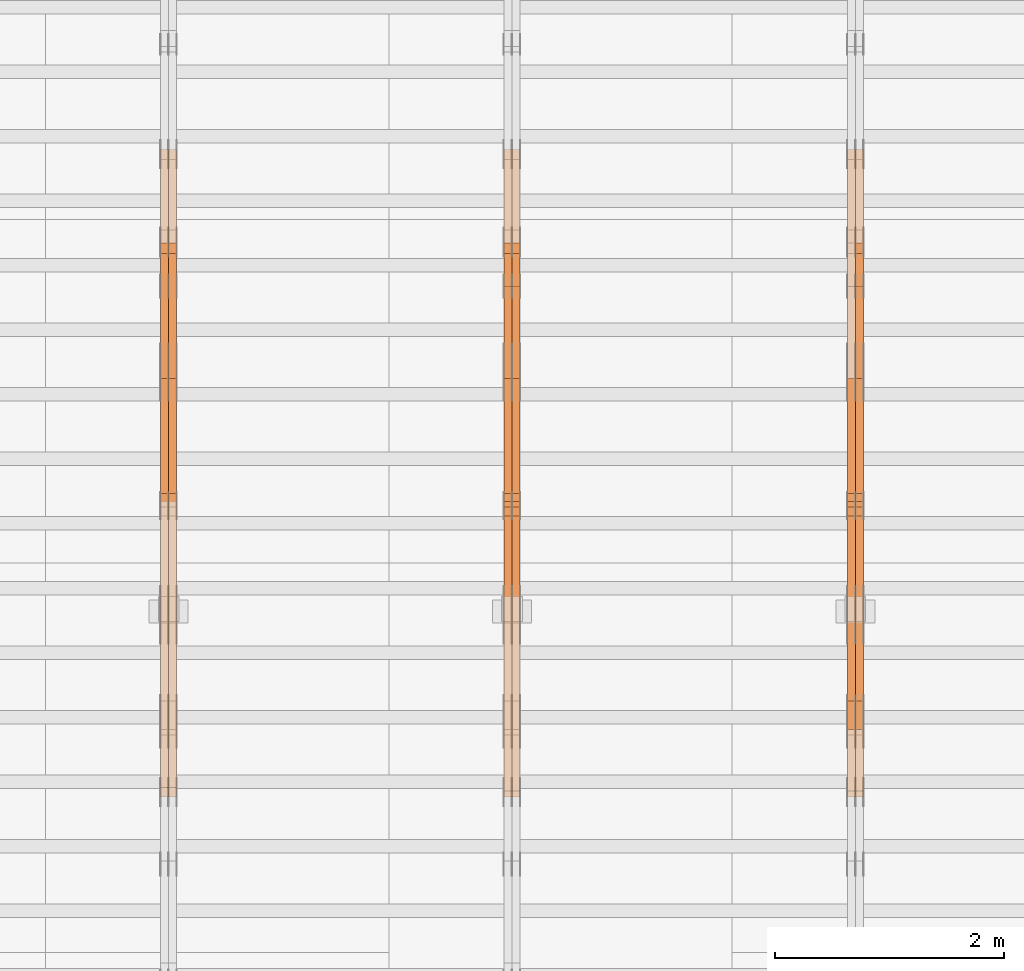
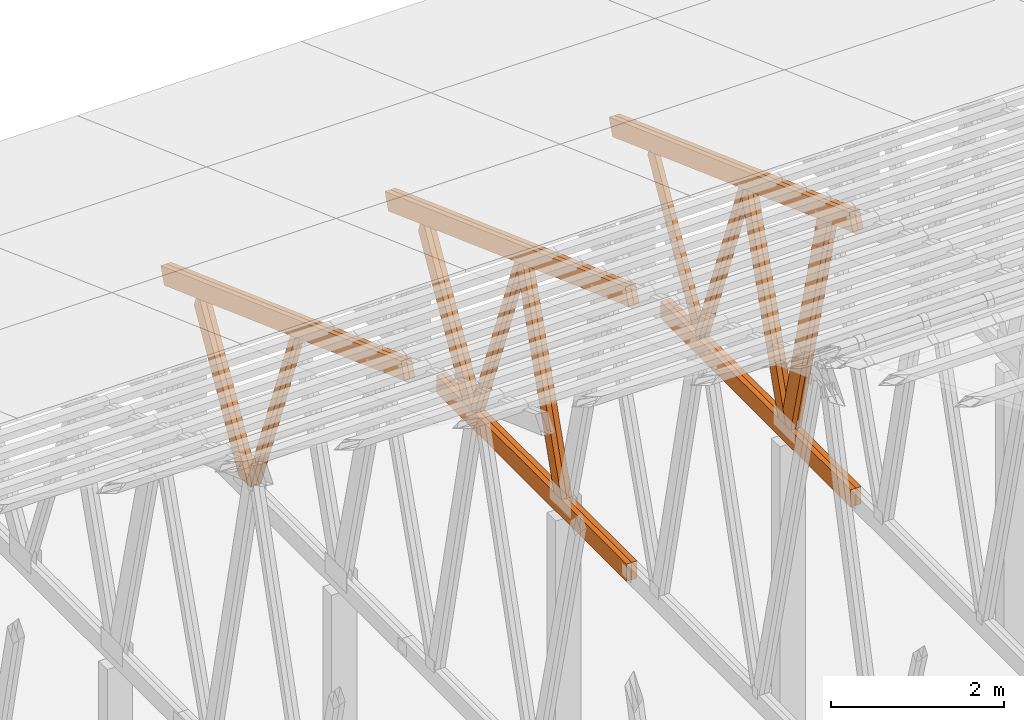
# One storey, part 39 of 189: 27 proxies.
"""IFC2X3 building model written with IfcOpenShell, lengths in millimetres."""

from ifc_helpers import new_model, entity, si_unit, converted_unit, derived_unit, direction, frame, origin, origin_2d_with_axis, place, context, subcontext, project, spatial, polyline, rectangle, outline, extrude, source, transform, mapped, material, type_object, type_shapes, element, save


model = new_model("IFC2X3")

# Units and contexts
model_context = context("Model", 3, precision=0.01, world=origin(), true_north=direction((6.12303176911189e-17, 1.0)))
body_context = subcontext(model_context, "Body", "Model", "MODEL_VIEW")
ifc_project = project(units=[si_unit("LENGTHUNIT", "METRE", prefix="MILLI"), si_unit("AREAUNIT", "SQUARE_METRE"), si_unit("VOLUMEUNIT", "CUBIC_METRE"), converted_unit("PLANEANGLEUNIT", "DEGREE", entity("IfcRatioMeasure", 0.0174532925199433), si_unit("PLANEANGLEUNIT", "RADIAN"), dimensions=[0, 0, 0, 0, 0, 0, 0]), si_unit("MASSUNIT", "GRAM", prefix="KILO"), derived_unit("MASSDENSITYUNIT", [(si_unit("MASSUNIT", "GRAM", prefix="KILO"), 1), (si_unit("LENGTHUNIT", "METRE"), -3)]), si_unit("TIMEUNIT", "SECOND"), si_unit("FREQUENCYUNIT", "HERTZ"), si_unit("THERMODYNAMICTEMPERATUREUNIT", "DEGREE_CELSIUS"), derived_unit("THERMALTRANSMITTANCEUNIT", [(si_unit("MASSUNIT", "GRAM", prefix="KILO"), 1), (si_unit("THERMODYNAMICTEMPERATUREUNIT", "KELVIN"), -1), (si_unit("TIMEUNIT", "SECOND"), -3)]), derived_unit("VOLUMETRICFLOWRATEUNIT", [(si_unit("LENGTHUNIT", "METRE"), 3), (si_unit("TIMEUNIT", "SECOND"), -1)]), si_unit("ELECTRICCURRENTUNIT", "AMPERE"), si_unit("ELECTRICVOLTAGEUNIT", "VOLT"), si_unit("POWERUNIT", "WATT"), si_unit("FORCEUNIT", "NEWTON"), si_unit("ILLUMINANCEUNIT", "LUX"), si_unit("LUMINOUSFLUXUNIT", "LUMEN"), si_unit("LUMINOUSINTENSITYUNIT", "CANDELA"), derived_unit("USERDEFINED", [(si_unit("MASSUNIT", "GRAM", prefix="KILO"), -1), (si_unit("LENGTHUNIT", "METRE"), -2), (si_unit("TIMEUNIT", "SECOND"), 3), (si_unit("LUMINOUSFLUXUNIT", "LUMEN"), 1)]), derived_unit("LINEARVELOCITYUNIT", [(si_unit("LENGTHUNIT", "METRE"), 1), (si_unit("TIMEUNIT", "SECOND"), -1)]), si_unit("PRESSUREUNIT", "PASCAL"), derived_unit("USERDEFINED", [(si_unit("LENGTHUNIT", "METRE"), -2), (si_unit("MASSUNIT", "GRAM", prefix="KILO"), 1), (si_unit("TIMEUNIT", "SECOND"), -2)])], contexts=[model_context])

# Site, building, storey
site_placement = place(None, origin())
site = spatial("IfcSite", under=ifc_project, at=site_placement, CompositionType="ELEMENT")
building_placement = place(site_placement, origin())
building = spatial("IfcBuilding", under=site, at=building_placement, CompositionType="ELEMENT")
storey_placement = place(building_placement, origin())
storey = spatial("IfcBuildingStorey", under=building, at=storey_placement, Name="Default", CompositionType="ELEMENT", Elevation=0.0)

# Proxies
ifc_material_1 = material(Name="IfcSurfaceStyle #114816")
building_element_proxy_type_1 = type_object("IfcBuildingElementProxyType", Name="T1-W1 114814", PredefinedType="NOTDEFINED", material=ifc_material_1)
shared_shape_1 = source(origin(), body_context, "Body", "SweptSolid", [
    extrude(outline(polyline([(-1996.99427801396, -109.999889649051), (1271.09905152223, -109.999889649051), (1448.88120817726, -0.000113190727324008), (1421.70802776002, 109.999946244415), (-2144.69400944554, 109.999946244415), (-1996.99427801396, -109.999889649051)])), frame((1448.88120817726, 110.000265670598, 0.0), z_axis=(0.0, 0.0, 1.0), x_axis=(-1.0, 0.0, 0.0)), (0.0, 0.0, 1.0), 69.9999999999998),
])
type_shapes(building_element_proxy_type_1, [shared_shape_1])
proxy_1_placement = place(building_placement, frame((21300.0, 20558.6774904859, 218.61972674968), z_axis=(-1.0, 0.0, 0.0), x_axis=(0.0, -0.239819839925979, 0.970817410421691)))
element("IfcBuildingElementProxy", 1, at=proxy_1_placement, inside=storey, type_object=building_element_proxy_type_1, material=ifc_material_1, Name="T1-W1", context=body_context, shape_type="MappedRepresentation", body=[
    mapped(shared_shape_1, transform((0.0, 0.0, 0.0), scale=1.0)),
])
ifc_material_2 = material(Name="IfcSurfaceStyle #114750")
building_element_proxy_type_2 = type_object("IfcBuildingElementProxyType", Name="T1-W1 114748", PredefinedType="NOTDEFINED", material=ifc_material_2)
shared_shape_2 = source(origin(), body_context, "Body", "SweptSolid", [
    extrude(outline(polyline([(-1996.99427801396, -109.999889649051), (1271.09905152223, -109.999889649051), (1448.88120817726, -0.000113190727324008), (1421.70802776002, 109.999946244415), (-2144.69400944554, 109.999946244415), (-1996.99427801396, -109.999889649051)])), frame((1448.88120817726, 110.000265670598, 0.0), z_axis=(0.0, 0.0, 1.0), x_axis=(-1.0, 0.0, 0.0)), (0.0, 0.0, 1.0), 69.9999999999998),
])
type_shapes(building_element_proxy_type_2, [shared_shape_2])
proxy_2_placement = place(building_placement, frame((21230.0, 20558.6774904859, 218.61972674968), z_axis=(-1.0, 0.0, 0.0), x_axis=(0.0, -0.239819839925979, 0.970817410421691)))
element("IfcBuildingElementProxy", 2, at=proxy_2_placement, inside=storey, type_object=building_element_proxy_type_2, material=ifc_material_2, Name="T1-W1", context=body_context, shape_type="MappedRepresentation", body=[
    mapped(shared_shape_2, transform((0.0, 0.0, 0.0), scale=1.0)),
])
ifc_material_3 = material(Name="IfcSurfaceStyle #114552")
building_element_proxy_type_3 = type_object("IfcBuildingElementProxyType", Name="T1-W4 114550", PredefinedType="NOTDEFINED", material=ifc_material_3)
shared_shape_3 = source(origin(), body_context, "Body", "SweptSolid", [
    extrude(outline(polyline([(-1742.90513395849, -84.9997422414737), (1181.3544167489, -84.9997422414737), (1178.19398821251, -0.000208932978430543), (1071.44989130457, 84.999846707963), (-1688.09316230749, 84.999846707963), (-1742.90513395849, -84.9997422414737)])), frame((1181.35452116422, 84.999886337523, 0.0), z_axis=(0.0, 0.0, 1.0), x_axis=(-1.0, 0.0, 0.0)), (0.0, 0.0, 1.0), 69.9999999999998),
])
type_shapes(building_element_proxy_type_3, [shared_shape_3])
proxy_3_placement = place(building_placement, frame((21300.0, 21724.6281517871, 2976.00232464744), z_axis=(-1.0, 0.0, 0.0), x_axis=(0.0, -0.306868406216495, -0.951751953644514)))
element("IfcBuildingElementProxy", 3, at=proxy_3_placement, inside=storey, type_object=building_element_proxy_type_3, material=ifc_material_3, Name="T1-W4", context=body_context, shape_type="MappedRepresentation", body=[
    mapped(shared_shape_3, transform((0.0, 0.0, 0.0), scale=1.0)),
])
ifc_material_4 = material(Name="IfcSurfaceStyle #114486")
building_element_proxy_type_4 = type_object("IfcBuildingElementProxyType", Name="T1-W4 114484", PredefinedType="NOTDEFINED", material=ifc_material_4)
shared_shape_4 = source(origin(), body_context, "Body", "SweptSolid", [
    extrude(outline(polyline([(-1742.90513395849, -84.9997422414737), (1181.3544167489, -84.9997422414737), (1178.19398821251, -0.000208932978430543), (1071.44989130457, 84.999846707963), (-1688.09316230749, 84.999846707963), (-1742.90513395849, -84.9997422414737)])), frame((1181.35452116422, 84.999886337523, 0.0), z_axis=(0.0, 0.0, 1.0), x_axis=(-1.0, 0.0, 0.0)), (0.0, 0.0, 1.0), 69.9999999999998),
])
type_shapes(building_element_proxy_type_4, [shared_shape_4])
proxy_4_placement = place(building_placement, frame((21230.0, 21724.6281517871, 2976.00232464744), z_axis=(-1.0, 0.0, 0.0), x_axis=(0.0, -0.306868406216495, -0.951751953644514)))
element("IfcBuildingElementProxy", 4, at=proxy_4_placement, inside=storey, type_object=building_element_proxy_type_4, material=ifc_material_4, Name="T1-W4", context=body_context, shape_type="MappedRepresentation", body=[
    mapped(shared_shape_4, transform((0.0, 0.0, 0.0), scale=1.0)),
])
ifc_material_5 = material(Name="IfcSurfaceStyle #114288")
building_element_proxy_type_5 = type_object("IfcBuildingElementProxyType", Name="T1-W8 114286", PredefinedType="NOTDEFINED", material=ifc_material_5)
shared_shape_5 = source(origin(), body_context, "Body", "SweptSolid", [
    extrude(outline(polyline([(-1700.10906247918, -47.4998559987011), (1140.60243146647, -47.4998559987011), (1179.56122089033, 0.000120838919977206), (1161.65086478184, 47.4997955792411), (-1781.70545465947, 47.4997955792411), (-1700.10906247918, -47.4998559987011)])), frame((1179.56128464708, 47.5000634692093, 0.0), z_axis=(0.0, 0.0, 1.0), x_axis=(-1.0, 0.0, 0.0)), (0.0, 0.0, 1.0), 69.9999999999998),
])
type_shapes(building_element_proxy_type_5, [shared_shape_5])
proxy_5_placement = place(building_placement, frame((21300.0, 22687.5385403115, 228.241249073207), z_axis=(-1.0, 0.0, 0.0), x_axis=(0.0, -0.352814979177604, 0.93569310698963)))
element("IfcBuildingElementProxy", 5, at=proxy_5_placement, inside=storey, type_object=building_element_proxy_type_5, material=ifc_material_5, Name="T1-W8", context=body_context, shape_type="MappedRepresentation", body=[
    mapped(shared_shape_5, transform((0.0, 0.0, 0.0), scale=1.0)),
])
ifc_material_6 = material(Name="IfcSurfaceStyle #114222")
building_element_proxy_type_6 = type_object("IfcBuildingElementProxyType", Name="T1-W8 114220", PredefinedType="NOTDEFINED", material=ifc_material_6)
shared_shape_6 = source(origin(), body_context, "Body", "SweptSolid", [
    extrude(outline(polyline([(-1700.10906247918, -47.4998559987011), (1140.60243146647, -47.4998559987011), (1179.56122089033, 0.000120838919977206), (1161.65086478184, 47.4997955792411), (-1781.70545465947, 47.4997955792411), (-1700.10906247918, -47.4998559987011)])), frame((1179.56128464708, 47.5000634692093, 0.0), z_axis=(0.0, 0.0, 1.0), x_axis=(-1.0, 0.0, 0.0)), (0.0, 0.0, 1.0), 69.9999999999998),
])
type_shapes(building_element_proxy_type_6, [shared_shape_6])
proxy_6_placement = place(building_placement, frame((21230.0, 22687.5385403115, 228.241249073207), z_axis=(-1.0, 0.0, 0.0), x_axis=(0.0, -0.352814979177604, 0.93569310698963)))
element("IfcBuildingElementProxy", 6, at=proxy_6_placement, inside=storey, type_object=building_element_proxy_type_6, material=ifc_material_6, Name="T1-W8", context=body_context, shape_type="MappedRepresentation", body=[
    mapped(shared_shape_6, transform((0.0, 0.0, 0.0), scale=1.0)),
])
ifc_material_7 = material(Name="IfcSurfaceStyle #114024")
building_element_proxy_type_7 = type_object("IfcBuildingElementProxyType", Name="T1-W2 114022", PredefinedType="NOTDEFINED", material=ifc_material_7)
shared_shape_7 = source(origin(), body_context, "Body", "SweptSolid", [
    extrude(outline(polyline([(-1361.89144606429, -97.5000598486876), (887.613245225805, -97.5000598486876), (904.774262962339, 0.000302345139042259), (818.892339969004, 97.4999086761182), (-1249.38840209286, 97.4999086761182), (-1361.89144606429, -97.5000598486876)])), frame((904.774262962339, 97.5000966763391, 0.0), z_axis=(0.0, 0.0, 1.0), x_axis=(-1.0, 0.0, 0.0)), (0.0, 0.0, 1.0), 69.9999999999999),
])
type_shapes(building_element_proxy_type_7, [shared_shape_7])
proxy_7_placement = place(building_placement, frame((21300.0, 24033.6159173732, 2110.89189244614), z_axis=(-1.0, 0.0, 0.0), x_axis=(0.0, -0.5, -0.866025403784439)))
element("IfcBuildingElementProxy", 7, at=proxy_7_placement, inside=storey, type_object=building_element_proxy_type_7, material=ifc_material_7, Name="T1-W2", context=body_context, shape_type="MappedRepresentation", body=[
    mapped(shared_shape_7, transform((0.0, 0.0, 0.0), scale=1.0)),
])
ifc_material_8 = material(Name="IfcSurfaceStyle #111948")
building_element_proxy_type_8 = type_object("IfcBuildingElementProxyType", Name="T1-B4 111946", PredefinedType="NOTDEFINED", material=ifc_material_8)
shared_shape_8 = source(origin(), body_context, "Body", "SweptSolid", [
    extrude(rectangle(XDim=4408.2412109375, YDim=245.000000000001, at=origin_2d_with_axis()), frame((2204.12060546875, 122.5, 0.0), z_axis=(0.0, 0.0, 1.0), x_axis=(-1.0, 0.0, 0.0)), (0.0, 0.0, 1.0), 69.9999999999997),
])
type_shapes(building_element_proxy_type_8, [shared_shape_8])
proxy_8_placement = place(building_placement, frame((21300.0, 19161.7587890625, 245.0), z_axis=(-1.0, 0.0, 0.0), x_axis=(0.0, 1.0, 0.0)))
element("IfcBuildingElementProxy", 8, at=proxy_8_placement, inside=storey, type_object=building_element_proxy_type_8, material=ifc_material_8, Name="T1-B4", context=body_context, shape_type="MappedRepresentation", body=[
    mapped(shared_shape_8, transform((0.0, 0.0, 0.0), scale=1.0)),
])
ifc_material_9 = material(Name="IfcSurfaceStyle #111891")
building_element_proxy_type_9 = type_object("IfcBuildingElementProxyType", Name="T1-B4 111889", PredefinedType="NOTDEFINED", material=ifc_material_9)
shared_shape_9 = source(origin(), body_context, "Body", "SweptSolid", [
    extrude(rectangle(XDim=4408.2412109375, YDim=245.000000000001, at=origin_2d_with_axis()), frame((2204.12060546875, 122.5, 0.0), z_axis=(0.0, 0.0, 1.0), x_axis=(-1.0, 0.0, 0.0)), (0.0, 0.0, 1.0), 69.9999999999997),
])
type_shapes(building_element_proxy_type_9, [shared_shape_9])
proxy_9_placement = place(building_placement, frame((21230.0, 19161.7587890625, 245.0), z_axis=(-1.0, 0.0, 0.0), x_axis=(0.0, 1.0, 0.0)))
element("IfcBuildingElementProxy", 9, at=proxy_9_placement, inside=storey, type_object=building_element_proxy_type_9, material=ifc_material_9, Name="T1-B4", context=body_context, shape_type="MappedRepresentation", body=[
    mapped(shared_shape_9, transform((0.0, 0.0, 0.0), scale=1.0)),
])
ifc_material_10 = material(Name="IfcSurfaceStyle #110904")
building_element_proxy_type_10 = type_object("IfcBuildingElementProxyType", Name="T1-T1 110902", PredefinedType="NOTDEFINED", material=ifc_material_10)
shared_shape_10 = source(origin(), body_context, "Body", "SweptSolid", [
    extrude(outline(polyline([(-2964.99982426074, -122.499947708046), (2964.99981923522, -122.499947708046), (2964.99984513599, 122.499947708046), (-2964.99984011047, 122.499947708046), (-2964.99982426074, -122.499947708046)])), frame((2964.99984513599, 122.499998966405, 0.0), z_axis=(0.0, 0.0, 1.0), x_axis=(-1.0, 0.0, 0.0)), (0.0, 0.0, 1.0), 69.9999999999996),
])
type_shapes(building_element_proxy_type_10, [shared_shape_10])
proxy_10_placement = place(building_placement, frame((21300.0, 24681.3398262186, 1893.12531804384), z_axis=(-1.0, 0.0, 0.0), x_axis=(0.0, -0.939692620785908, 0.342020143325669)))
element("IfcBuildingElementProxy", 10, at=proxy_10_placement, inside=storey, type_object=building_element_proxy_type_10, material=ifc_material_10, Name="T1-T1", context=body_context, shape_type="MappedRepresentation", body=[
    mapped(shared_shape_10, transform((0.0, 0.0, 0.0), scale=1.0)),
])
ifc_material_11 = material(Name="IfcSurfaceStyle #110847")
building_element_proxy_type_11 = type_object("IfcBuildingElementProxyType", Name="T1-T1 110845", PredefinedType="NOTDEFINED", material=ifc_material_11)
shared_shape_11 = source(origin(), body_context, "Body", "SweptSolid", [
    extrude(outline(polyline([(-2964.99982426074, -122.499947708046), (2964.99981923522, -122.499947708046), (2964.99984513599, 122.499947708046), (-2964.99984011047, 122.499947708046), (-2964.99982426074, -122.499947708046)])), frame((2964.99984513599, 122.499998966405, 0.0), z_axis=(0.0, 0.0, 1.0), x_axis=(-1.0, 0.0, 0.0)), (0.0, 0.0, 1.0), 69.9999999999996),
])
type_shapes(building_element_proxy_type_11, [shared_shape_11])
proxy_11_placement = place(building_placement, frame((21230.0, 24681.3398262186, 1893.12531804384), z_axis=(-1.0, 0.0, 0.0), x_axis=(0.0, -0.939692620785908, 0.342020143325669)))
element("IfcBuildingElementProxy", 11, at=proxy_11_placement, inside=storey, type_object=building_element_proxy_type_11, material=ifc_material_11, Name="T1-T1", context=body_context, shape_type="MappedRepresentation", body=[
    mapped(shared_shape_11, transform((0.0, 0.0, 0.0), scale=1.0)),
])
ifc_material_12 = material(Name="IfcSurfaceStyle #98762")
building_element_proxy_type_12 = type_object("IfcBuildingElementProxyType", Name="T1-W4 98760", PredefinedType="NOTDEFINED", material=ifc_material_12)
shared_shape_12 = source(origin(), body_context, "Body", "SweptSolid", [
    extrude(outline(polyline([(-1742.90513395849, -84.9997422414737), (1181.3544167489, -84.9997422414737), (1178.19398821251, -0.000208932978430543), (1071.44989130457, 84.999846707963), (-1688.09316230749, 84.999846707963), (-1742.90513395849, -84.9997422414737)])), frame((1181.35452116422, 84.999886337523, 0.0), z_axis=(0.0, 0.0, 1.0), x_axis=(-1.0, 0.0, 0.0)), (0.0, 0.0, 1.0), 69.9999999999998),
])
type_shapes(building_element_proxy_type_12, [shared_shape_12])
proxy_12_placement = place(building_placement, frame((18300.0, 21724.6281517871, 2976.00232464744), z_axis=(-1.0, 0.0, 0.0), x_axis=(0.0, -0.306868406216495, -0.951751953644514)))
element("IfcBuildingElementProxy", 12, at=proxy_12_placement, inside=storey, type_object=building_element_proxy_type_12, material=ifc_material_12, Name="T1-W4", context=body_context, shape_type="MappedRepresentation", body=[
    mapped(shared_shape_12, transform((0.0, 0.0, 0.0), scale=1.0)),
])
ifc_material_13 = material(Name="IfcSurfaceStyle #98696")
building_element_proxy_type_13 = type_object("IfcBuildingElementProxyType", Name="T1-W4 98694", PredefinedType="NOTDEFINED", material=ifc_material_13)
shared_shape_13 = source(origin(), body_context, "Body", "SweptSolid", [
    extrude(outline(polyline([(-1742.90513395849, -84.9997422414737), (1181.3544167489, -84.9997422414737), (1178.19398821251, -0.000208932978430543), (1071.44989130457, 84.999846707963), (-1688.09316230749, 84.999846707963), (-1742.90513395849, -84.9997422414737)])), frame((1181.35452116422, 84.999886337523, 0.0), z_axis=(0.0, 0.0, 1.0), x_axis=(-1.0, 0.0, 0.0)), (0.0, 0.0, 1.0), 69.9999999999998),
])
type_shapes(building_element_proxy_type_13, [shared_shape_13])
proxy_13_placement = place(building_placement, frame((18230.0, 21724.6281517871, 2976.00232464744), z_axis=(-1.0, 0.0, 0.0), x_axis=(0.0, -0.306868406216495, -0.951751953644514)))
element("IfcBuildingElementProxy", 13, at=proxy_13_placement, inside=storey, type_object=building_element_proxy_type_13, material=ifc_material_13, Name="T1-W4", context=body_context, shape_type="MappedRepresentation", body=[
    mapped(shared_shape_13, transform((0.0, 0.0, 0.0), scale=1.0)),
])
ifc_material_14 = material(Name="IfcSurfaceStyle #98498")
building_element_proxy_type_14 = type_object("IfcBuildingElementProxyType", Name="T1-W8 98496", PredefinedType="NOTDEFINED", material=ifc_material_14)
shared_shape_14 = source(origin(), body_context, "Body", "SweptSolid", [
    extrude(outline(polyline([(-1700.10906247918, -47.4998559987011), (1140.60243146647, -47.4998559987011), (1179.56122089033, 0.000120838919977206), (1161.65086478184, 47.4997955792411), (-1781.70545465947, 47.4997955792411), (-1700.10906247918, -47.4998559987011)])), frame((1179.56128464708, 47.5000634692093, 0.0), z_axis=(0.0, 0.0, 1.0), x_axis=(-1.0, 0.0, 0.0)), (0.0, 0.0, 1.0), 69.9999999999998),
])
type_shapes(building_element_proxy_type_14, [shared_shape_14])
proxy_14_placement = place(building_placement, frame((18300.0, 22687.5385403115, 228.241249073207), z_axis=(-1.0, 0.0, 0.0), x_axis=(0.0, -0.352814979177604, 0.93569310698963)))
element("IfcBuildingElementProxy", 14, at=proxy_14_placement, inside=storey, type_object=building_element_proxy_type_14, material=ifc_material_14, Name="T1-W8", context=body_context, shape_type="MappedRepresentation", body=[
    mapped(shared_shape_14, transform((0.0, 0.0, 0.0), scale=1.0)),
])
ifc_material_15 = material(Name="IfcSurfaceStyle #98432")
building_element_proxy_type_15 = type_object("IfcBuildingElementProxyType", Name="T1-W8 98430", PredefinedType="NOTDEFINED", material=ifc_material_15)
shared_shape_15 = source(origin(), body_context, "Body", "SweptSolid", [
    extrude(outline(polyline([(-1700.10906247918, -47.4998559987011), (1140.60243146647, -47.4998559987011), (1179.56122089033, 0.000120838919977206), (1161.65086478184, 47.4997955792411), (-1781.70545465947, 47.4997955792411), (-1700.10906247918, -47.4998559987011)])), frame((1179.56128464708, 47.5000634692093, 0.0), z_axis=(0.0, 0.0, 1.0), x_axis=(-1.0, 0.0, 0.0)), (0.0, 0.0, 1.0), 69.9999999999998),
])
type_shapes(building_element_proxy_type_15, [shared_shape_15])
proxy_15_placement = place(building_placement, frame((18230.0, 22687.5385403115, 228.241249073207), z_axis=(-1.0, 0.0, 0.0), x_axis=(0.0, -0.352814979177604, 0.93569310698963)))
element("IfcBuildingElementProxy", 15, at=proxy_15_placement, inside=storey, type_object=building_element_proxy_type_15, material=ifc_material_15, Name="T1-W8", context=body_context, shape_type="MappedRepresentation", body=[
    mapped(shared_shape_15, transform((0.0, 0.0, 0.0), scale=1.0)),
])
ifc_material_16 = material(Name="IfcSurfaceStyle #98234")
building_element_proxy_type_16 = type_object("IfcBuildingElementProxyType", Name="T1-W2 98232", PredefinedType="NOTDEFINED", material=ifc_material_16)
shared_shape_16 = source(origin(), body_context, "Body", "SweptSolid", [
    extrude(outline(polyline([(-1361.89144606429, -97.5000598486876), (887.613245225805, -97.5000598486876), (904.774262962339, 0.000302345139042259), (818.892339969004, 97.4999086761182), (-1249.38840209286, 97.4999086761182), (-1361.89144606429, -97.5000598486876)])), frame((904.774262962339, 97.5000966763391, 0.0), z_axis=(0.0, 0.0, 1.0), x_axis=(-1.0, 0.0, 0.0)), (0.0, 0.0, 1.0), 69.9999999999999),
])
type_shapes(building_element_proxy_type_16, [shared_shape_16])
proxy_16_placement = place(building_placement, frame((18300.0, 24033.6159173732, 2110.89189244614), z_axis=(-1.0, 0.0, 0.0), x_axis=(0.0, -0.5, -0.866025403784439)))
element("IfcBuildingElementProxy", 16, at=proxy_16_placement, inside=storey, type_object=building_element_proxy_type_16, material=ifc_material_16, Name="T1-W2", context=body_context, shape_type="MappedRepresentation", body=[
    mapped(shared_shape_16, transform((0.0, 0.0, 0.0), scale=1.0)),
])
ifc_material_17 = material(Name="IfcSurfaceStyle #98168")
building_element_proxy_type_17 = type_object("IfcBuildingElementProxyType", Name="T1-W2 98166", PredefinedType="NOTDEFINED", material=ifc_material_17)
shared_shape_17 = source(origin(), body_context, "Body", "SweptSolid", [
    extrude(outline(polyline([(-1361.89144606429, -97.5000598486876), (887.613245225805, -97.5000598486876), (904.774262962339, 0.000302345139042259), (818.892339969004, 97.4999086761182), (-1249.38840209286, 97.4999086761182), (-1361.89144606429, -97.5000598486876)])), frame((904.774262962339, 97.5000966763391, 0.0), z_axis=(0.0, 0.0, 1.0), x_axis=(-1.0, 0.0, 0.0)), (0.0, 0.0, 1.0), 69.9999999999999),
])
type_shapes(building_element_proxy_type_17, [shared_shape_17])
proxy_17_placement = place(building_placement, frame((18230.0, 24033.6159173732, 2110.89189244614), z_axis=(-1.0, 0.0, 0.0), x_axis=(0.0, -0.5, -0.866025403784439)))
element("IfcBuildingElementProxy", 17, at=proxy_17_placement, inside=storey, type_object=building_element_proxy_type_17, material=ifc_material_17, Name="T1-W2", context=body_context, shape_type="MappedRepresentation", body=[
    mapped(shared_shape_17, transform((0.0, 0.0, 0.0), scale=1.0)),
])
ifc_material_18 = material(Name="IfcSurfaceStyle #96158")
building_element_proxy_type_18 = type_object("IfcBuildingElementProxyType", Name="T1-B4 96156", PredefinedType="NOTDEFINED", material=ifc_material_18)
shared_shape_18 = source(origin(), body_context, "Body", "SweptSolid", [
    extrude(rectangle(XDim=4408.2412109375, YDim=245.000000000001, at=origin_2d_with_axis()), frame((2204.12060546875, 122.5, 0.0), z_axis=(0.0, 0.0, 1.0), x_axis=(-1.0, 0.0, 0.0)), (0.0, 0.0, 1.0), 69.9999999999997),
])
type_shapes(building_element_proxy_type_18, [shared_shape_18])
proxy_18_placement = place(building_placement, frame((18300.0, 19161.7587890625, 245.0), z_axis=(-1.0, 0.0, 0.0), x_axis=(0.0, 1.0, 0.0)))
element("IfcBuildingElementProxy", 18, at=proxy_18_placement, inside=storey, type_object=building_element_proxy_type_18, material=ifc_material_18, Name="T1-B4", context=body_context, shape_type="MappedRepresentation", body=[
    mapped(shared_shape_18, transform((0.0, 0.0, 0.0), scale=1.0)),
])
ifc_material_19 = material(Name="IfcSurfaceStyle #96101")
building_element_proxy_type_19 = type_object("IfcBuildingElementProxyType", Name="T1-B4 96099", PredefinedType="NOTDEFINED", material=ifc_material_19)
shared_shape_19 = source(origin(), body_context, "Body", "SweptSolid", [
    extrude(rectangle(XDim=4408.2412109375, YDim=245.000000000001, at=origin_2d_with_axis()), frame((2204.12060546875, 122.5, 0.0), z_axis=(0.0, 0.0, 1.0), x_axis=(-1.0, 0.0, 0.0)), (0.0, 0.0, 1.0), 69.9999999999997),
])
type_shapes(building_element_proxy_type_19, [shared_shape_19])
proxy_19_placement = place(building_placement, frame((18230.0, 19161.7587890625, 245.0), z_axis=(-1.0, 0.0, 0.0), x_axis=(0.0, 1.0, 0.0)))
element("IfcBuildingElementProxy", 19, at=proxy_19_placement, inside=storey, type_object=building_element_proxy_type_19, material=ifc_material_19, Name="T1-B4", context=body_context, shape_type="MappedRepresentation", body=[
    mapped(shared_shape_19, transform((0.0, 0.0, 0.0), scale=1.0)),
])
ifc_material_20 = material(Name="IfcSurfaceStyle #95114")
building_element_proxy_type_20 = type_object("IfcBuildingElementProxyType", Name="T1-T1 95112", PredefinedType="NOTDEFINED", material=ifc_material_20)
shared_shape_20 = source(origin(), body_context, "Body", "SweptSolid", [
    extrude(outline(polyline([(-2964.99982426074, -122.499947708046), (2964.99981923522, -122.499947708046), (2964.99984513599, 122.499947708046), (-2964.99984011047, 122.499947708046), (-2964.99982426074, -122.499947708046)])), frame((2964.99984513599, 122.499998966405, 0.0), z_axis=(0.0, 0.0, 1.0), x_axis=(-1.0, 0.0, 0.0)), (0.0, 0.0, 1.0), 69.9999999999996),
])
type_shapes(building_element_proxy_type_20, [shared_shape_20])
proxy_20_placement = place(building_placement, frame((18300.0, 24681.3398262186, 1893.12531804384), z_axis=(-1.0, 0.0, 0.0), x_axis=(0.0, -0.939692620785908, 0.342020143325669)))
element("IfcBuildingElementProxy", 20, at=proxy_20_placement, inside=storey, type_object=building_element_proxy_type_20, material=ifc_material_20, Name="T1-T1", context=body_context, shape_type="MappedRepresentation", body=[
    mapped(shared_shape_20, transform((0.0, 0.0, 0.0), scale=1.0)),
])
ifc_material_21 = material(Name="IfcSurfaceStyle #95057")
building_element_proxy_type_21 = type_object("IfcBuildingElementProxyType", Name="T1-T1 95055", PredefinedType="NOTDEFINED", material=ifc_material_21)
shared_shape_21 = source(origin(), body_context, "Body", "SweptSolid", [
    extrude(outline(polyline([(-2964.99982426074, -122.499947708046), (2964.99981923522, -122.499947708046), (2964.99984513599, 122.499947708046), (-2964.99984011047, 122.499947708046), (-2964.99982426074, -122.499947708046)])), frame((2964.99984513599, 122.499998966405, 0.0), z_axis=(0.0, 0.0, 1.0), x_axis=(-1.0, 0.0, 0.0)), (0.0, 0.0, 1.0), 69.9999999999996),
])
type_shapes(building_element_proxy_type_21, [shared_shape_21])
proxy_21_placement = place(building_placement, frame((18230.0, 24681.3398262186, 1893.12531804384), z_axis=(-1.0, 0.0, 0.0), x_axis=(0.0, -0.939692620785908, 0.342020143325669)))
element("IfcBuildingElementProxy", 21, at=proxy_21_placement, inside=storey, type_object=building_element_proxy_type_21, material=ifc_material_21, Name="T1-T1", context=body_context, shape_type="MappedRepresentation", body=[
    mapped(shared_shape_21, transform((0.0, 0.0, 0.0), scale=1.0)),
])
ifc_material_22 = material(Name="IfcSurfaceStyle #82708")
building_element_proxy_type_22 = type_object("IfcBuildingElementProxyType", Name="T1-W8 82706", PredefinedType="NOTDEFINED", material=ifc_material_22)
shared_shape_22 = source(origin(), body_context, "Body", "SweptSolid", [
    extrude(outline(polyline([(-1700.10906247918, -47.4998559987011), (1140.60243146647, -47.4998559987011), (1179.56122089033, 0.000120838919977206), (1161.65086478184, 47.4997955792411), (-1781.70545465947, 47.4997955792411), (-1700.10906247918, -47.4998559987011)])), frame((1179.56128464708, 47.5000634692093, 0.0), z_axis=(0.0, 0.0, 1.0), x_axis=(-1.0, 0.0, 0.0)), (0.0, 0.0, 1.0), 69.9999999999998),
])
type_shapes(building_element_proxy_type_22, [shared_shape_22])
proxy_22_placement = place(building_placement, frame((15300.0, 22687.5385403115, 228.241249073207), z_axis=(-1.0, 0.0, 0.0), x_axis=(0.0, -0.352814979177604, 0.93569310698963)))
element("IfcBuildingElementProxy", 22, at=proxy_22_placement, inside=storey, type_object=building_element_proxy_type_22, material=ifc_material_22, Name="T1-W8", context=body_context, shape_type="MappedRepresentation", body=[
    mapped(shared_shape_22, transform((0.0, 0.0, 0.0), scale=1.0)),
])
ifc_material_23 = material(Name="IfcSurfaceStyle #82642")
building_element_proxy_type_23 = type_object("IfcBuildingElementProxyType", Name="T1-W8 82640", PredefinedType="NOTDEFINED", material=ifc_material_23)
shared_shape_23 = source(origin(), body_context, "Body", "SweptSolid", [
    extrude(outline(polyline([(-1700.10906247918, -47.4998559987011), (1140.60243146647, -47.4998559987011), (1179.56122089033, 0.000120838919977206), (1161.65086478184, 47.4997955792411), (-1781.70545465947, 47.4997955792411), (-1700.10906247918, -47.4998559987011)])), frame((1179.56128464708, 47.5000634692093, 0.0), z_axis=(0.0, 0.0, 1.0), x_axis=(-1.0, 0.0, 0.0)), (0.0, 0.0, 1.0), 69.9999999999998),
])
type_shapes(building_element_proxy_type_23, [shared_shape_23])
proxy_23_placement = place(building_placement, frame((15230.0, 22687.5385403115, 228.241249073207), z_axis=(-1.0, 0.0, 0.0), x_axis=(0.0, -0.352814979177604, 0.93569310698963)))
element("IfcBuildingElementProxy", 23, at=proxy_23_placement, inside=storey, type_object=building_element_proxy_type_23, material=ifc_material_23, Name="T1-W8", context=body_context, shape_type="MappedRepresentation", body=[
    mapped(shared_shape_23, transform((0.0, 0.0, 0.0), scale=1.0)),
])
ifc_material_24 = material(Name="IfcSurfaceStyle #82444")
building_element_proxy_type_24 = type_object("IfcBuildingElementProxyType", Name="T1-W2 82442", PredefinedType="NOTDEFINED", material=ifc_material_24)
shared_shape_24 = source(origin(), body_context, "Body", "SweptSolid", [
    extrude(outline(polyline([(-1361.89144606429, -97.5000598486876), (887.613245225805, -97.5000598486876), (904.774262962339, 0.000302345139042259), (818.892339969004, 97.4999086761182), (-1249.38840209286, 97.4999086761182), (-1361.89144606429, -97.5000598486876)])), frame((904.774262962339, 97.5000966763391, 0.0), z_axis=(0.0, 0.0, 1.0), x_axis=(-1.0, 0.0, 0.0)), (0.0, 0.0, 1.0), 69.9999999999999),
])
type_shapes(building_element_proxy_type_24, [shared_shape_24])
proxy_24_placement = place(building_placement, frame((15300.0, 24033.6159173732, 2110.89189244614), z_axis=(-1.0, 0.0, 0.0), x_axis=(0.0, -0.5, -0.866025403784439)))
element("IfcBuildingElementProxy", 24, at=proxy_24_placement, inside=storey, type_object=building_element_proxy_type_24, material=ifc_material_24, Name="T1-W2", context=body_context, shape_type="MappedRepresentation", body=[
    mapped(shared_shape_24, transform((0.0, 0.0, 0.0), scale=1.0)),
])
ifc_material_25 = material(Name="IfcSurfaceStyle #82378")
building_element_proxy_type_25 = type_object("IfcBuildingElementProxyType", Name="T1-W2 82376", PredefinedType="NOTDEFINED", material=ifc_material_25)
shared_shape_25 = source(origin(), body_context, "Body", "SweptSolid", [
    extrude(outline(polyline([(-1361.89144606429, -97.5000598486876), (887.613245225805, -97.5000598486876), (904.774262962339, 0.000302345139042259), (818.892339969004, 97.4999086761182), (-1249.38840209286, 97.4999086761182), (-1361.89144606429, -97.5000598486876)])), frame((904.774262962339, 97.5000966763391, 0.0), z_axis=(0.0, 0.0, 1.0), x_axis=(-1.0, 0.0, 0.0)), (0.0, 0.0, 1.0), 69.9999999999999),
])
type_shapes(building_element_proxy_type_25, [shared_shape_25])
proxy_25_placement = place(building_placement, frame((15230.0, 24033.6159173732, 2110.89189244614), z_axis=(-1.0, 0.0, 0.0), x_axis=(0.0, -0.5, -0.866025403784439)))
element("IfcBuildingElementProxy", 25, at=proxy_25_placement, inside=storey, type_object=building_element_proxy_type_25, material=ifc_material_25, Name="T1-W2", context=body_context, shape_type="MappedRepresentation", body=[
    mapped(shared_shape_25, transform((0.0, 0.0, 0.0), scale=1.0)),
])
ifc_material_26 = material(Name="IfcSurfaceStyle #79324")
building_element_proxy_type_26 = type_object("IfcBuildingElementProxyType", Name="T1-T1 79322", PredefinedType="NOTDEFINED", material=ifc_material_26)
shared_shape_26 = source(origin(), body_context, "Body", "SweptSolid", [
    extrude(outline(polyline([(-2964.99982426074, -122.499947708046), (2964.99981923522, -122.499947708046), (2964.99984513599, 122.499947708046), (-2964.99984011047, 122.499947708046), (-2964.99982426074, -122.499947708046)])), frame((2964.99984513599, 122.499998966405, 0.0), z_axis=(0.0, 0.0, 1.0), x_axis=(-1.0, 0.0, 0.0)), (0.0, 0.0, 1.0), 69.9999999999996),
])
type_shapes(building_element_proxy_type_26, [shared_shape_26])
proxy_26_placement = place(building_placement, frame((15300.0, 24681.3398262186, 1893.12531804384), z_axis=(-1.0, 0.0, 0.0), x_axis=(0.0, -0.939692620785908, 0.342020143325669)))
element("IfcBuildingElementProxy", 26, at=proxy_26_placement, inside=storey, type_object=building_element_proxy_type_26, material=ifc_material_26, Name="T1-T1", context=body_context, shape_type="MappedRepresentation", body=[
    mapped(shared_shape_26, transform((0.0, 0.0, 0.0), scale=1.0)),
])
ifc_material_27 = material(Name="IfcSurfaceStyle #79267")
building_element_proxy_type_27 = type_object("IfcBuildingElementProxyType", Name="T1-T1 79265", PredefinedType="NOTDEFINED", material=ifc_material_27)
shared_shape_27 = source(origin(), body_context, "Body", "SweptSolid", [
    extrude(outline(polyline([(-2964.99982426074, -122.499947708046), (2964.99981923522, -122.499947708046), (2964.99984513599, 122.499947708046), (-2964.99984011047, 122.499947708046), (-2964.99982426074, -122.499947708046)])), frame((2964.99984513599, 122.499998966405, 0.0), z_axis=(0.0, 0.0, 1.0), x_axis=(-1.0, 0.0, 0.0)), (0.0, 0.0, 1.0), 69.9999999999996),
])
type_shapes(building_element_proxy_type_27, [shared_shape_27])
proxy_27_placement = place(building_placement, frame((15230.0, 24681.3398262186, 1893.12531804384), z_axis=(-1.0, 0.0, 0.0), x_axis=(0.0, -0.939692620785908, 0.342020143325669)))
element("IfcBuildingElementProxy", 27, at=proxy_27_placement, inside=storey, type_object=building_element_proxy_type_27, material=ifc_material_27, Name="T1-T1", context=body_context, shape_type="MappedRepresentation", body=[
    mapped(shared_shape_27, transform((0.0, 0.0, 0.0), scale=1.0)),
])

save(model, "model.ifc")
